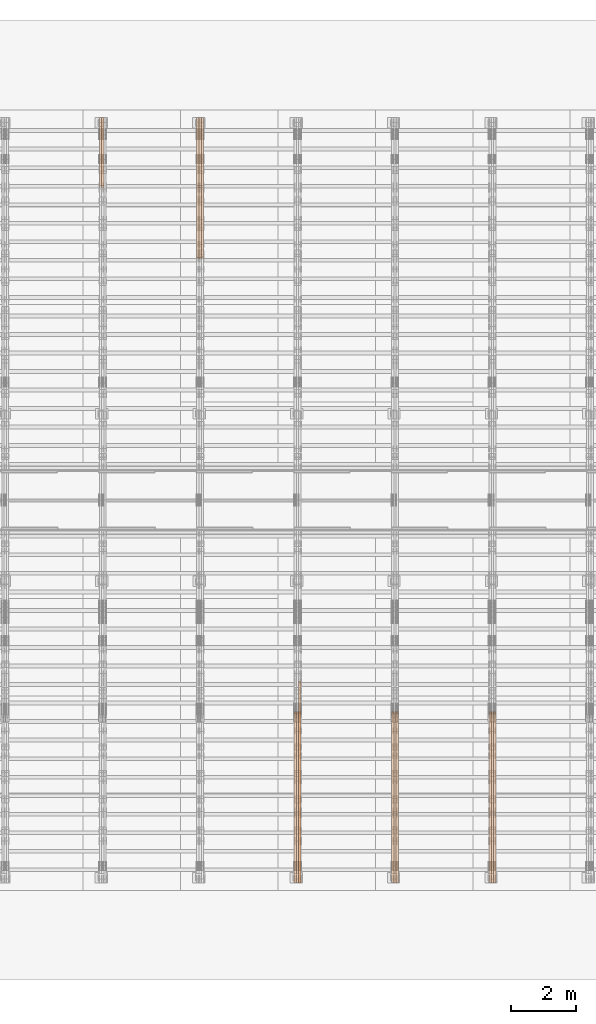
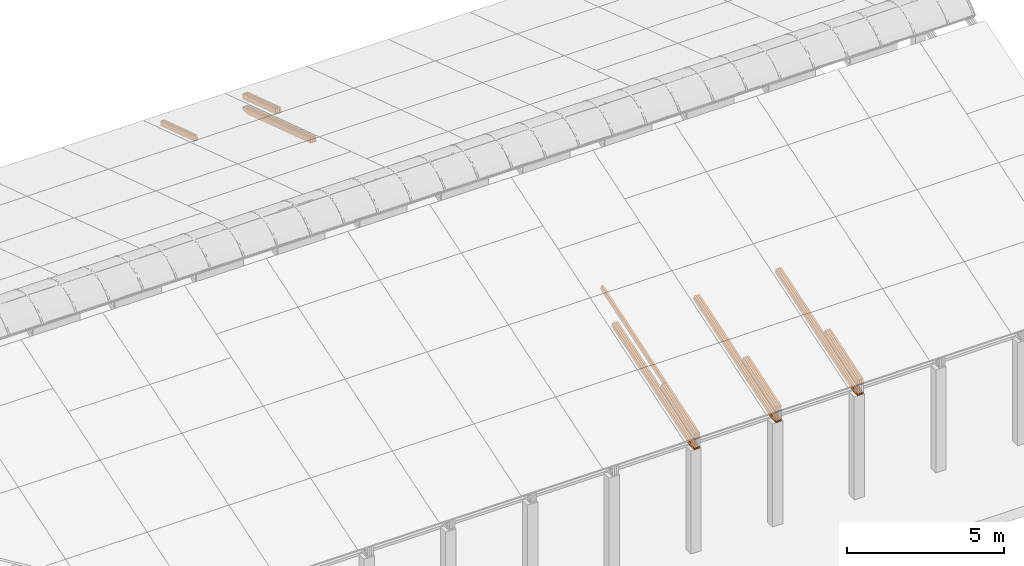
# One storey, part 24 of 385: 27 proxies.
"""IFC2X3 building model written with IfcOpenShell, lengths in millimetres."""

from ifc_helpers import new_model, entity, si_unit, converted_unit, derived_unit, direction, frame, origin, place, context, subcontext, project, spatial, polyline, outline, extrude, source, transform, mapped, material, type_object, type_shapes, element, save


model = new_model("IFC2X3")

# Units and contexts
model_context = context("Model", 3, precision=0.01, world=origin(), true_north=direction((6.12303176911189e-17, 1.0)))
body_context = subcontext(model_context, "Body", "Model", "MODEL_VIEW")
ifc_project = project(units=[si_unit("LENGTHUNIT", "METRE", prefix="MILLI"), si_unit("AREAUNIT", "SQUARE_METRE"), si_unit("VOLUMEUNIT", "CUBIC_METRE"), converted_unit("PLANEANGLEUNIT", "DEGREE", entity("IfcRatioMeasure", 0.0174532925199433), si_unit("PLANEANGLEUNIT", "RADIAN"), dimensions=[0, 0, 0, 0, 0, 0, 0]), si_unit("MASSUNIT", "GRAM", prefix="KILO"), derived_unit("MASSDENSITYUNIT", [(si_unit("MASSUNIT", "GRAM", prefix="KILO"), 1), (si_unit("LENGTHUNIT", "METRE"), -3)]), si_unit("TIMEUNIT", "SECOND"), si_unit("FREQUENCYUNIT", "HERTZ"), si_unit("THERMODYNAMICTEMPERATUREUNIT", "DEGREE_CELSIUS"), derived_unit("THERMALTRANSMITTANCEUNIT", [(si_unit("MASSUNIT", "GRAM", prefix="KILO"), 1), (si_unit("THERMODYNAMICTEMPERATUREUNIT", "KELVIN"), -1), (si_unit("TIMEUNIT", "SECOND"), -3)]), derived_unit("VOLUMETRICFLOWRATEUNIT", [(si_unit("LENGTHUNIT", "METRE"), 3), (si_unit("TIMEUNIT", "SECOND"), -1)]), si_unit("ELECTRICCURRENTUNIT", "AMPERE"), si_unit("ELECTRICVOLTAGEUNIT", "VOLT"), si_unit("POWERUNIT", "WATT"), si_unit("FORCEUNIT", "NEWTON", prefix="KILO"), si_unit("ILLUMINANCEUNIT", "LUX"), si_unit("LUMINOUSFLUXUNIT", "LUMEN"), si_unit("LUMINOUSINTENSITYUNIT", "CANDELA"), derived_unit("USERDEFINED", [(si_unit("MASSUNIT", "GRAM", prefix="KILO"), -1), (si_unit("LENGTHUNIT", "METRE"), -2), (si_unit("TIMEUNIT", "SECOND"), 3), (si_unit("LUMINOUSFLUXUNIT", "LUMEN"), 1)]), derived_unit("LINEARVELOCITYUNIT", [(si_unit("LENGTHUNIT", "METRE"), 1), (si_unit("TIMEUNIT", "SECOND"), -1)]), si_unit("PRESSUREUNIT", "PASCAL"), derived_unit("USERDEFINED", [(si_unit("LENGTHUNIT", "METRE"), -2), (si_unit("MASSUNIT", "GRAM", prefix="KILO"), 1), (si_unit("TIMEUNIT", "SECOND"), -2)])], contexts=[model_context])

# Site, building, storey
site_placement = place(None, origin())
site = spatial("IfcSite", under=ifc_project, at=site_placement, CompositionType="ELEMENT")
building_placement = place(site_placement, origin())
building = spatial("IfcBuilding", under=site, at=building_placement, CompositionType="ELEMENT")
storey_placement = place(building_placement, origin())
storey = spatial("IfcBuildingStorey", under=building, at=storey_placement, Name="Default", CompositionType="ELEMENT", Elevation=0.0)

# Proxies
ifc_material_1 = material(Name="IfcSurfaceStyle #455463")
building_element_proxy_type_1 = type_object("IfcBuildingElementProxyType", Name="T1-T3 455461", PredefinedType="NOTDEFINED", material=ifc_material_1)
shared_shape_1 = source(origin(), body_context, "Body", "SweptSolid", [
    extrude(outline(polyline([(-1085.54462735035, -97.5001496742589), (1117.22361141796, -97.5001496742589), (1117.22498157786, 97.5001496742589), (-1148.90396564547, 97.5001496742589), (-1085.54462735035, -97.5001496742589)])), frame((1117.22498157786, 97.5001496742589, 0.0), z_axis=(0.0, 0.0, 1.0), x_axis=(-1.0, 0.0, 0.0)), (0.0, 0.0, 1.0), 69.9999999999999),
])
type_shapes(building_element_proxy_type_1, [shared_shape_1])
proxy_1_placement = place(building_placement, frame((39385.0, 5095.216796875, 1095.23693847656), z_axis=(-1.0, 0.0, 0.0), x_axis=(0.0, -0.951056516295154, -0.309016994374948)))
element("IfcBuildingElementProxy", 1, at=proxy_1_placement, inside=storey, type_object=building_element_proxy_type_1, material=ifc_material_1, Name="T1-T3", context=body_context, shape_type="MappedRepresentation", body=[
    mapped(shared_shape_1, transform((0.0, 0.0, 0.0), scale=1.0)),
])
ifc_material_2 = material(Name="IfcSurfaceStyle #455406")
building_element_proxy_type_2 = type_object("IfcBuildingElementProxyType", Name="T1-T3 455404", PredefinedType="NOTDEFINED", material=ifc_material_2)
shared_shape_2 = source(origin(), body_context, "Body", "SweptSolid", [
    extrude(outline(polyline([(-1085.54462735035, -97.5001496742589), (1117.22361141796, -97.5001496742589), (1117.22498157786, 97.5001496742589), (-1148.90396564547, 97.5001496742589), (-1085.54462735035, -97.5001496742589)])), frame((1117.22498157786, 97.5001496742589, 0.0), z_axis=(0.0, 0.0, 1.0), x_axis=(-1.0, 0.0, 0.0)), (0.0, 0.0, 1.0), 69.9999999999999),
])
type_shapes(building_element_proxy_type_2, [shared_shape_2])
proxy_2_placement = place(building_placement, frame((39315.0, 5095.216796875, 1095.23693847656), z_axis=(-1.0, 0.0, 0.0), x_axis=(0.0, -0.951056516295154, -0.309016994374948)))
element("IfcBuildingElementProxy", 2, at=proxy_2_placement, inside=storey, type_object=building_element_proxy_type_2, material=ifc_material_2, Name="T1-T3", context=body_context, shape_type="MappedRepresentation", body=[
    mapped(shared_shape_2, transform((0.0, 0.0, 0.0), scale=1.0)),
])
ifc_material_3 = material(Name="IfcSurfaceStyle #455349")
building_element_proxy_type_3 = type_object("IfcBuildingElementProxyType", Name="T1-T3 455347", PredefinedType="NOTDEFINED", material=ifc_material_3)
shared_shape_3 = source(origin(), body_context, "Body", "SweptSolid", [
    extrude(outline(polyline([(-1085.54462735035, -97.5001496742589), (1117.22361141796, -97.5001496742589), (1117.22498157786, 97.5001496742589), (-1148.90396564547, 97.5001496742589), (-1085.54462735035, -97.5001496742589)])), frame((1117.22498157786, 97.5001496742589, 0.0), z_axis=(0.0, 0.0, 1.0), x_axis=(-1.0, 0.0, 0.0)), (0.0, 0.0, 1.0), 69.9999999999999),
])
type_shapes(building_element_proxy_type_3, [shared_shape_3])
proxy_3_placement = place(building_placement, frame((39245.0, 5095.216796875, 1095.23693847656), z_axis=(-1.0, 0.0, 0.0), x_axis=(0.0, -0.951056516295154, -0.309016994374948)))
element("IfcBuildingElementProxy", 3, at=proxy_3_placement, inside=storey, type_object=building_element_proxy_type_3, material=ifc_material_3, Name="T1-T3", context=body_context, shape_type="MappedRepresentation", body=[
    mapped(shared_shape_3, transform((0.0, 0.0, 0.0), scale=1.0)),
])
ifc_material_4 = material(Name="IfcSurfaceStyle #454779")
building_element_proxy_type_4 = type_object("IfcBuildingElementProxyType", Name="T1-B5 454777", PredefinedType="NOTDEFINED", material=ifc_material_4)
shared_shape_4 = source(origin(), body_context, "Body", "SweptSolid", [
    extrude(outline(polyline([(-3238.20553797979, -89.0131148793731), (1950.26357999126, -89.0131148793731), (2273.6227955316, 16.0525968934038), (2252.52438864378, 80.9868164326712), (-3238.20522618685, 80.9868164326712), (-3238.20553797979, -89.0131148793731)])), frame((2273.6227955316, 80.9869419088758, 0.0), z_axis=(0.0, 0.0, 1.0), x_axis=(-1.0, 0.0, 0.0)), (0.0, 0.0, 1.0), 69.9999999999997),
])
type_shapes(building_element_proxy_type_4, [shared_shape_4])
proxy_4_placement = place(building_placement, frame((39385.0, 2919.93418387161, 61.7562319586341), z_axis=(-1.0, 0.0, 0.0), x_axis=(0.0, 0.951056516295124, 0.309016994375039)))
element("IfcBuildingElementProxy", 4, at=proxy_4_placement, inside=storey, type_object=building_element_proxy_type_4, material=ifc_material_4, Name="T1-B5", context=body_context, shape_type="MappedRepresentation", body=[
    mapped(shared_shape_4, transform((0.0, 0.0, 0.0), scale=1.0)),
])
ifc_material_5 = material(Name="IfcSurfaceStyle #454713")
building_element_proxy_type_5 = type_object("IfcBuildingElementProxyType", Name="T1-B5 454711", PredefinedType="NOTDEFINED", material=ifc_material_5)
shared_shape_5 = source(origin(), body_context, "Body", "SweptSolid", [
    extrude(outline(polyline([(-3238.20553797979, -89.0131148793731), (1950.26357999126, -89.0131148793731), (2273.6227955316, 16.0525968934038), (2252.52438864378, 80.9868164326712), (-3238.20522618685, 80.9868164326712), (-3238.20553797979, -89.0131148793731)])), frame((2273.6227955316, 80.9869419088758, 0.0), z_axis=(0.0, 0.0, 1.0), x_axis=(-1.0, 0.0, 0.0)), (0.0, 0.0, 1.0), 69.9999999999997),
])
type_shapes(building_element_proxy_type_5, [shared_shape_5])
proxy_5_placement = place(building_placement, frame((39315.0, 2919.93418387161, 61.7562319586341), z_axis=(-1.0, 0.0, 0.0), x_axis=(0.0, 0.951056516295124, 0.309016994375039)))
element("IfcBuildingElementProxy", 5, at=proxy_5_placement, inside=storey, type_object=building_element_proxy_type_5, material=ifc_material_5, Name="T1-B5", context=body_context, shape_type="MappedRepresentation", body=[
    mapped(shared_shape_5, transform((0.0, 0.0, 0.0), scale=1.0)),
])
ifc_material_6 = material(Name="IfcSurfaceStyle #454647")
building_element_proxy_type_6 = type_object("IfcBuildingElementProxyType", Name="T1-B5 454645", PredefinedType="NOTDEFINED", material=ifc_material_6)
shared_shape_6 = source(origin(), body_context, "Body", "SweptSolid", [
    extrude(outline(polyline([(-3238.20553797979, -89.0131148793731), (1950.26357999126, -89.0131148793731), (2273.6227955316, 16.0525968934038), (2252.52438864378, 80.9868164326712), (-3238.20522618685, 80.9868164326712), (-3238.20553797979, -89.0131148793731)])), frame((2273.6227955316, 80.9869419088758, 0.0), z_axis=(0.0, 0.0, 1.0), x_axis=(-1.0, 0.0, 0.0)), (0.0, 0.0, 1.0), 69.9999999999997),
])
type_shapes(building_element_proxy_type_6, [shared_shape_6])
proxy_6_placement = place(building_placement, frame((39245.0, 2919.93418387161, 61.7562319586341), z_axis=(-1.0, 0.0, 0.0), x_axis=(0.0, 0.951056516295124, 0.309016994375039)))
element("IfcBuildingElementProxy", 6, at=proxy_6_placement, inside=storey, type_object=building_element_proxy_type_6, material=ifc_material_6, Name="T1-B5", context=body_context, shape_type="MappedRepresentation", body=[
    mapped(shared_shape_6, transform((0.0, 0.0, 0.0), scale=1.0)),
])
ifc_material_7 = material(Name="IfcSurfaceStyle #421031")
building_element_proxy_type_7 = type_object("IfcBuildingElementProxyType", Name="T1-T3 421029", PredefinedType="NOTDEFINED", material=ifc_material_7)
shared_shape_7 = source(origin(), body_context, "Body", "SweptSolid", [
    extrude(outline(polyline([(-1085.54462735035, -97.5001496742589), (1117.22361141796, -97.5001496742589), (1117.22498157786, 97.5001496742589), (-1148.90396564547, 97.5001496742589), (-1085.54462735035, -97.5001496742589)])), frame((1117.22498157786, 97.5001496742589, 0.0), z_axis=(0.0, 0.0, 1.0), x_axis=(-1.0, 0.0, 0.0)), (0.0, 0.0, 1.0), 69.9999999999999),
])
type_shapes(building_element_proxy_type_7, [shared_shape_7])
proxy_7_placement = place(building_placement, frame((36385.0, 5095.216796875, 1095.23693847656), z_axis=(-1.0, 0.0, 0.0), x_axis=(0.0, -0.951056516295154, -0.309016994374948)))
element("IfcBuildingElementProxy", 7, at=proxy_7_placement, inside=storey, type_object=building_element_proxy_type_7, material=ifc_material_7, Name="T1-T3", context=body_context, shape_type="MappedRepresentation", body=[
    mapped(shared_shape_7, transform((0.0, 0.0, 0.0), scale=1.0)),
])
ifc_material_8 = material(Name="IfcSurfaceStyle #420974")
building_element_proxy_type_8 = type_object("IfcBuildingElementProxyType", Name="T1-T3 420972", PredefinedType="NOTDEFINED", material=ifc_material_8)
shared_shape_8 = source(origin(), body_context, "Body", "SweptSolid", [
    extrude(outline(polyline([(-1085.54462735035, -97.5001496742589), (1117.22361141796, -97.5001496742589), (1117.22498157786, 97.5001496742589), (-1148.90396564547, 97.5001496742589), (-1085.54462735035, -97.5001496742589)])), frame((1117.22498157786, 97.5001496742589, 0.0), z_axis=(0.0, 0.0, 1.0), x_axis=(-1.0, 0.0, 0.0)), (0.0, 0.0, 1.0), 69.9999999999999),
])
type_shapes(building_element_proxy_type_8, [shared_shape_8])
proxy_8_placement = place(building_placement, frame((36315.0, 5095.216796875, 1095.23693847656), z_axis=(-1.0, 0.0, 0.0), x_axis=(0.0, -0.951056516295154, -0.309016994374948)))
element("IfcBuildingElementProxy", 8, at=proxy_8_placement, inside=storey, type_object=building_element_proxy_type_8, material=ifc_material_8, Name="T1-T3", context=body_context, shape_type="MappedRepresentation", body=[
    mapped(shared_shape_8, transform((0.0, 0.0, 0.0), scale=1.0)),
])
ifc_material_9 = material(Name="IfcSurfaceStyle #420917")
building_element_proxy_type_9 = type_object("IfcBuildingElementProxyType", Name="T1-T3 420915", PredefinedType="NOTDEFINED", material=ifc_material_9)
shared_shape_9 = source(origin(), body_context, "Body", "SweptSolid", [
    extrude(outline(polyline([(-1085.54462735035, -97.5001496742589), (1117.22361141796, -97.5001496742589), (1117.22498157786, 97.5001496742589), (-1148.90396564547, 97.5001496742589), (-1085.54462735035, -97.5001496742589)])), frame((1117.22498157786, 97.5001496742589, 0.0), z_axis=(0.0, 0.0, 1.0), x_axis=(-1.0, 0.0, 0.0)), (0.0, 0.0, 1.0), 69.9999999999999),
])
type_shapes(building_element_proxy_type_9, [shared_shape_9])
proxy_9_placement = place(building_placement, frame((36245.0, 5095.216796875, 1095.23693847656), z_axis=(-1.0, 0.0, 0.0), x_axis=(0.0, -0.951056516295154, -0.309016994374948)))
element("IfcBuildingElementProxy", 9, at=proxy_9_placement, inside=storey, type_object=building_element_proxy_type_9, material=ifc_material_9, Name="T1-T3", context=body_context, shape_type="MappedRepresentation", body=[
    mapped(shared_shape_9, transform((0.0, 0.0, 0.0), scale=1.0)),
])
ifc_material_10 = material(Name="IfcSurfaceStyle #420347")
building_element_proxy_type_10 = type_object("IfcBuildingElementProxyType", Name="T1-B5 420345", PredefinedType="NOTDEFINED", material=ifc_material_10)
shared_shape_10 = source(origin(), body_context, "Body", "SweptSolid", [
    extrude(outline(polyline([(-3238.20553797979, -89.0131148793731), (1950.26357999126, -89.0131148793731), (2273.6227955316, 16.0525968934038), (2252.52438864378, 80.9868164326712), (-3238.20522618685, 80.9868164326712), (-3238.20553797979, -89.0131148793731)])), frame((2273.6227955316, 80.9869419088758, 0.0), z_axis=(0.0, 0.0, 1.0), x_axis=(-1.0, 0.0, 0.0)), (0.0, 0.0, 1.0), 69.9999999999997),
])
type_shapes(building_element_proxy_type_10, [shared_shape_10])
proxy_10_placement = place(building_placement, frame((36385.0, 2919.93418387161, 61.7562319586341), z_axis=(-1.0, 0.0, 0.0), x_axis=(0.0, 0.951056516295124, 0.309016994375039)))
element("IfcBuildingElementProxy", 10, at=proxy_10_placement, inside=storey, type_object=building_element_proxy_type_10, material=ifc_material_10, Name="T1-B5", context=body_context, shape_type="MappedRepresentation", body=[
    mapped(shared_shape_10, transform((0.0, 0.0, 0.0), scale=1.0)),
])
ifc_material_11 = material(Name="IfcSurfaceStyle #420281")
building_element_proxy_type_11 = type_object("IfcBuildingElementProxyType", Name="T1-B5 420279", PredefinedType="NOTDEFINED", material=ifc_material_11)
shared_shape_11 = source(origin(), body_context, "Body", "SweptSolid", [
    extrude(outline(polyline([(-3238.20553797979, -89.0131148793731), (1950.26357999126, -89.0131148793731), (2273.6227955316, 16.0525968934038), (2252.52438864378, 80.9868164326712), (-3238.20522618685, 80.9868164326712), (-3238.20553797979, -89.0131148793731)])), frame((2273.6227955316, 80.9869419088758, 0.0), z_axis=(0.0, 0.0, 1.0), x_axis=(-1.0, 0.0, 0.0)), (0.0, 0.0, 1.0), 69.9999999999997),
])
type_shapes(building_element_proxy_type_11, [shared_shape_11])
proxy_11_placement = place(building_placement, frame((36315.0, 2919.93418387161, 61.7562319586341), z_axis=(-1.0, 0.0, 0.0), x_axis=(0.0, 0.951056516295124, 0.309016994375039)))
element("IfcBuildingElementProxy", 11, at=proxy_11_placement, inside=storey, type_object=building_element_proxy_type_11, material=ifc_material_11, Name="T1-B5", context=body_context, shape_type="MappedRepresentation", body=[
    mapped(shared_shape_11, transform((0.0, 0.0, 0.0), scale=1.0)),
])
ifc_material_12 = material(Name="IfcSurfaceStyle #420215")
building_element_proxy_type_12 = type_object("IfcBuildingElementProxyType", Name="T1-B5 420213", PredefinedType="NOTDEFINED", material=ifc_material_12)
shared_shape_12 = source(origin(), body_context, "Body", "SweptSolid", [
    extrude(outline(polyline([(-3238.20553797979, -89.0131148793731), (1950.26357999126, -89.0131148793731), (2273.6227955316, 16.0525968934038), (2252.52438864378, 80.9868164326712), (-3238.20522618685, 80.9868164326712), (-3238.20553797979, -89.0131148793731)])), frame((2273.6227955316, 80.9869419088758, 0.0), z_axis=(0.0, 0.0, 1.0), x_axis=(-1.0, 0.0, 0.0)), (0.0, 0.0, 1.0), 69.9999999999997),
])
type_shapes(building_element_proxy_type_12, [shared_shape_12])
proxy_12_placement = place(building_placement, frame((36245.0, 2919.93418387161, 61.7562319586341), z_axis=(-1.0, 0.0, 0.0), x_axis=(0.0, 0.951056516295124, 0.309016994375039)))
element("IfcBuildingElementProxy", 12, at=proxy_12_placement, inside=storey, type_object=building_element_proxy_type_12, material=ifc_material_12, Name="T1-B5", context=body_context, shape_type="MappedRepresentation", body=[
    mapped(shared_shape_12, transform((0.0, 0.0, 0.0), scale=1.0)),
])
ifc_material_13 = material(Name="IfcSurfaceStyle #386599")
building_element_proxy_type_13 = type_object("IfcBuildingElementProxyType", Name="T1-T3 386597", PredefinedType="NOTDEFINED", material=ifc_material_13)
shared_shape_13 = source(origin(), body_context, "Body", "SweptSolid", [
    extrude(outline(polyline([(-1085.54462735035, -97.5001496742589), (1117.22361141796, -97.5001496742589), (1117.22498157786, 97.5001496742589), (-1148.90396564547, 97.5001496742589), (-1085.54462735035, -97.5001496742589)])), frame((1117.22498157786, 97.5001496742589, 0.0), z_axis=(0.0, 0.0, 1.0), x_axis=(-1.0, 0.0, 0.0)), (0.0, 0.0, 1.0), 69.9999999999999),
])
type_shapes(building_element_proxy_type_13, [shared_shape_13])
proxy_13_placement = place(building_placement, frame((33385.0, 5095.216796875, 1095.23693847656), z_axis=(-1.0, 0.0, 0.0), x_axis=(0.0, -0.951056516295154, -0.309016994374948)))
element("IfcBuildingElementProxy", 13, at=proxy_13_placement, inside=storey, type_object=building_element_proxy_type_13, material=ifc_material_13, Name="T1-T3", context=body_context, shape_type="MappedRepresentation", body=[
    mapped(shared_shape_13, transform((0.0, 0.0, 0.0), scale=1.0)),
])
ifc_material_14 = material(Name="IfcSurfaceStyle #386542")
building_element_proxy_type_14 = type_object("IfcBuildingElementProxyType", Name="T1-T3 386540", PredefinedType="NOTDEFINED", material=ifc_material_14)
shared_shape_14 = source(origin(), body_context, "Body", "SweptSolid", [
    extrude(outline(polyline([(-1085.54462735035, -97.5001496742589), (1117.22361141796, -97.5001496742589), (1117.22498157786, 97.5001496742589), (-1148.90396564547, 97.5001496742589), (-1085.54462735035, -97.5001496742589)])), frame((1117.22498157786, 97.5001496742589, 0.0), z_axis=(0.0, 0.0, 1.0), x_axis=(-1.0, 0.0, 0.0)), (0.0, 0.0, 1.0), 69.9999999999999),
])
type_shapes(building_element_proxy_type_14, [shared_shape_14])
proxy_14_placement = place(building_placement, frame((33315.0, 5095.216796875, 1095.23693847656), z_axis=(-1.0, 0.0, 0.0), x_axis=(0.0, -0.951056516295154, -0.309016994374948)))
element("IfcBuildingElementProxy", 14, at=proxy_14_placement, inside=storey, type_object=building_element_proxy_type_14, material=ifc_material_14, Name="T1-T3", context=body_context, shape_type="MappedRepresentation", body=[
    mapped(shared_shape_14, transform((0.0, 0.0, 0.0), scale=1.0)),
])
ifc_material_15 = material(Name="IfcSurfaceStyle #386485")
building_element_proxy_type_15 = type_object("IfcBuildingElementProxyType", Name="T1-T3 386483", PredefinedType="NOTDEFINED", material=ifc_material_15)
shared_shape_15 = source(origin(), body_context, "Body", "SweptSolid", [
    extrude(outline(polyline([(-1085.54462735035, -97.5001496742589), (1117.22361141796, -97.5001496742589), (1117.22498157786, 97.5001496742589), (-1148.90396564547, 97.5001496742589), (-1085.54462735035, -97.5001496742589)])), frame((1117.22498157786, 97.5001496742589, 0.0), z_axis=(0.0, 0.0, 1.0), x_axis=(-1.0, 0.0, 0.0)), (0.0, 0.0, 1.0), 69.9999999999999),
])
type_shapes(building_element_proxy_type_15, [shared_shape_15])
proxy_15_placement = place(building_placement, frame((33245.0, 5095.216796875, 1095.23693847656), z_axis=(-1.0, 0.0, 0.0), x_axis=(0.0, -0.951056516295154, -0.309016994374948)))
element("IfcBuildingElementProxy", 15, at=proxy_15_placement, inside=storey, type_object=building_element_proxy_type_15, material=ifc_material_15, Name="T1-T3", context=body_context, shape_type="MappedRepresentation", body=[
    mapped(shared_shape_15, transform((0.0, 0.0, 0.0), scale=1.0)),
])
ifc_material_16 = material(Name="IfcSurfaceStyle #386428")
building_element_proxy_type_16 = type_object("IfcBuildingElementProxyType", Name="T1-T2 386426", PredefinedType="NOTDEFINED", material=ifc_material_16)
shared_shape_16 = source(origin(), body_context, "Body", "SweptSolid", [
    extrude(outline(polyline([(-2137.04475371072, -97.5001541485635), (2137.04431231695, -97.5001541485635), (2137.0438249446, 97.5001541485636), (-2137.04338355082, 97.5001541485635), (-2137.04475371072, -97.5001541485635)])), frame((2137.04431231695, 97.5003268035489, 0.0), z_axis=(0.0, 0.0, 1.0), x_axis=(-1.0, 0.0, 0.0)), (0.0, 0.0, 1.0), 69.9999999999997),
])
type_shapes(building_element_proxy_type_16, [shared_shape_16])
proxy_16_placement = place(building_placement, frame((33385.0, 9160.11575124697, 2416.00267194857), z_axis=(-1.0, 0.0, 0.0), x_axis=(0.0, -0.951056516295154, -0.309016994374948)))
element("IfcBuildingElementProxy", 16, at=proxy_16_placement, inside=storey, type_object=building_element_proxy_type_16, material=ifc_material_16, Name="T1-T2", context=body_context, shape_type="MappedRepresentation", body=[
    mapped(shared_shape_16, transform((0.0, 0.0, 0.0), scale=1.0)),
])
ifc_material_17 = material(Name="IfcSurfaceStyle #385915")
building_element_proxy_type_17 = type_object("IfcBuildingElementProxyType", Name="T1-B5 385913", PredefinedType="NOTDEFINED", material=ifc_material_17)
shared_shape_17 = source(origin(), body_context, "Body", "SweptSolid", [
    extrude(outline(polyline([(-3238.20553797979, -89.0131148793731), (1950.26357999126, -89.0131148793731), (2273.6227955316, 16.0525968934038), (2252.52438864378, 80.9868164326712), (-3238.20522618685, 80.9868164326712), (-3238.20553797979, -89.0131148793731)])), frame((2273.6227955316, 80.9869419088758, 0.0), z_axis=(0.0, 0.0, 1.0), x_axis=(-1.0, 0.0, 0.0)), (0.0, 0.0, 1.0), 69.9999999999997),
])
type_shapes(building_element_proxy_type_17, [shared_shape_17])
proxy_17_placement = place(building_placement, frame((33385.0, 2919.93418387161, 61.7562319586341), z_axis=(-1.0, 0.0, 0.0), x_axis=(0.0, 0.951056516295124, 0.309016994375039)))
element("IfcBuildingElementProxy", 17, at=proxy_17_placement, inside=storey, type_object=building_element_proxy_type_17, material=ifc_material_17, Name="T1-B5", context=body_context, shape_type="MappedRepresentation", body=[
    mapped(shared_shape_17, transform((0.0, 0.0, 0.0), scale=1.0)),
])
ifc_material_18 = material(Name="IfcSurfaceStyle #385849")
building_element_proxy_type_18 = type_object("IfcBuildingElementProxyType", Name="T1-B5 385847", PredefinedType="NOTDEFINED", material=ifc_material_18)
shared_shape_18 = source(origin(), body_context, "Body", "SweptSolid", [
    extrude(outline(polyline([(-3238.20553797979, -89.0131148793731), (1950.26357999126, -89.0131148793731), (2273.6227955316, 16.0525968934038), (2252.52438864378, 80.9868164326712), (-3238.20522618685, 80.9868164326712), (-3238.20553797979, -89.0131148793731)])), frame((2273.6227955316, 80.9869419088758, 0.0), z_axis=(0.0, 0.0, 1.0), x_axis=(-1.0, 0.0, 0.0)), (0.0, 0.0, 1.0), 69.9999999999997),
])
type_shapes(building_element_proxy_type_18, [shared_shape_18])
proxy_18_placement = place(building_placement, frame((33315.0, 2919.93418387161, 61.7562319586341), z_axis=(-1.0, 0.0, 0.0), x_axis=(0.0, 0.951056516295124, 0.309016994375039)))
element("IfcBuildingElementProxy", 18, at=proxy_18_placement, inside=storey, type_object=building_element_proxy_type_18, material=ifc_material_18, Name="T1-B5", context=body_context, shape_type="MappedRepresentation", body=[
    mapped(shared_shape_18, transform((0.0, 0.0, 0.0), scale=1.0)),
])
ifc_material_19 = material(Name="IfcSurfaceStyle #385783")
building_element_proxy_type_19 = type_object("IfcBuildingElementProxyType", Name="T1-B5 385781", PredefinedType="NOTDEFINED", material=ifc_material_19)
shared_shape_19 = source(origin(), body_context, "Body", "SweptSolid", [
    extrude(outline(polyline([(-3238.20553797979, -89.0131148793731), (1950.26357999126, -89.0131148793731), (2273.6227955316, 16.0525968934038), (2252.52438864378, 80.9868164326712), (-3238.20522618685, 80.9868164326712), (-3238.20553797979, -89.0131148793731)])), frame((2273.6227955316, 80.9869419088758, 0.0), z_axis=(0.0, 0.0, 1.0), x_axis=(-1.0, 0.0, 0.0)), (0.0, 0.0, 1.0), 69.9999999999997),
])
type_shapes(building_element_proxy_type_19, [shared_shape_19])
proxy_19_placement = place(building_placement, frame((33245.0, 2919.93418387161, 61.7562319586341), z_axis=(-1.0, 0.0, 0.0), x_axis=(0.0, 0.951056516295124, 0.309016994375039)))
element("IfcBuildingElementProxy", 19, at=proxy_19_placement, inside=storey, type_object=building_element_proxy_type_19, material=ifc_material_19, Name="T1-B5", context=body_context, shape_type="MappedRepresentation", body=[
    mapped(shared_shape_19, transform((0.0, 0.0, 0.0), scale=1.0)),
])
ifc_material_20 = material(Name="IfcSurfaceStyle #352338")
building_element_proxy_type_20 = type_object("IfcBuildingElementProxyType", Name="T1-T3 352336", PredefinedType="NOTDEFINED", material=ifc_material_20)
shared_shape_20 = source(origin(), body_context, "Body", "SweptSolid", [
    extrude(outline(polyline([(-1117.22419189679, -97.5000115568039), (1085.54451125458, -97.5000115568039), (1148.90384954971, 97.5000115568039), (-1117.2241689075, 97.5000115568039), (-1117.22419189679, -97.5000115568039)])), frame((1148.90385201956, 97.5000191595882, 0.0), z_axis=(0.0, 0.0, 1.0), x_axis=(-1.0, 0.0, 0.0)), (0.0, 0.0, 1.0), 69.9999999999999),
])
type_shapes(building_element_proxy_type_20, [shared_shape_20])
proxy_20_placement = place(building_placement, frame((30385.0, 26500.0, 394.964866273674), z_axis=(-1.0, 0.0, 0.0), x_axis=(0.0, -0.951056516295154, 0.309016994374948)))
element("IfcBuildingElementProxy", 20, at=proxy_20_placement, inside=storey, type_object=building_element_proxy_type_20, material=ifc_material_20, Name="T1-T3", context=body_context, shape_type="MappedRepresentation", body=[
    mapped(shared_shape_20, transform((0.0, 0.0, 0.0), scale=1.0)),
])
ifc_material_21 = material(Name="IfcSurfaceStyle #352281")
building_element_proxy_type_21 = type_object("IfcBuildingElementProxyType", Name="T1-T3 352279", PredefinedType="NOTDEFINED", material=ifc_material_21)
shared_shape_21 = source(origin(), body_context, "Body", "SweptSolid", [
    extrude(outline(polyline([(-1117.22419189679, -97.5000115568039), (1085.54451125458, -97.5000115568039), (1148.90384954971, 97.5000115568039), (-1117.2241689075, 97.5000115568039), (-1117.22419189679, -97.5000115568039)])), frame((1148.90385201956, 97.5000191595882, 0.0), z_axis=(0.0, 0.0, 1.0), x_axis=(-1.0, 0.0, 0.0)), (0.0, 0.0, 1.0), 69.9999999999999),
])
type_shapes(building_element_proxy_type_21, [shared_shape_21])
proxy_21_placement = place(building_placement, frame((30315.0, 26500.0, 394.964866273674), z_axis=(-1.0, 0.0, 0.0), x_axis=(0.0, -0.951056516295154, 0.309016994374948)))
element("IfcBuildingElementProxy", 21, at=proxy_21_placement, inside=storey, type_object=building_element_proxy_type_21, material=ifc_material_21, Name="T1-T3", context=body_context, shape_type="MappedRepresentation", body=[
    mapped(shared_shape_21, transform((0.0, 0.0, 0.0), scale=1.0)),
])
ifc_material_22 = material(Name="IfcSurfaceStyle #352224")
building_element_proxy_type_22 = type_object("IfcBuildingElementProxyType", Name="T1-T3 352222", PredefinedType="NOTDEFINED", material=ifc_material_22)
shared_shape_22 = source(origin(), body_context, "Body", "SweptSolid", [
    extrude(outline(polyline([(-1117.22419189679, -97.5000115568039), (1085.54451125458, -97.5000115568039), (1148.90384954971, 97.5000115568039), (-1117.2241689075, 97.5000115568039), (-1117.22419189679, -97.5000115568039)])), frame((1148.90385201956, 97.5000191595882, 0.0), z_axis=(0.0, 0.0, 1.0), x_axis=(-1.0, 0.0, 0.0)), (0.0, 0.0, 1.0), 69.9999999999999),
])
type_shapes(building_element_proxy_type_22, [shared_shape_22])
proxy_22_placement = place(building_placement, frame((30245.0, 26500.0, 394.964866273674), z_axis=(-1.0, 0.0, 0.0), x_axis=(0.0, -0.951056516295154, 0.309016994374948)))
element("IfcBuildingElementProxy", 22, at=proxy_22_placement, inside=storey, type_object=building_element_proxy_type_22, material=ifc_material_22, Name="T1-T3", context=body_context, shape_type="MappedRepresentation", body=[
    mapped(shared_shape_22, transform((0.0, 0.0, 0.0), scale=1.0)),
])
ifc_material_23 = material(Name="IfcSurfaceStyle #350943")
building_element_proxy_type_23 = type_object("IfcBuildingElementProxyType", Name="T1-B1 350941", PredefinedType="NOTDEFINED", material=ifc_material_23)
shared_shape_23 = source(origin(), body_context, "Body", "SweptSolid", [
    extrude(outline(polyline([(-2659.34106034305, -95.9868650736445), (1861.19950396595, -95.9868650736445), (1890.42090463564, -6.05260867570997), (1567.0616890952, 99.0131694114995), (-2659.34103735375, 99.0131694114995), (-2659.34106034305, -95.9868650736445)])), frame((1890.42090463564, 99.013169411504, 0.0), z_axis=(0.0, 0.0, 1.0), x_axis=(-1.0, 0.0, 0.0)), (0.0, 0.0, 1.0), 69.9999999999997),
])
type_shapes(building_element_proxy_type_23, [shared_shape_23])
proxy_23_placement = place(building_placement, frame((30385.0, 26467.5328890438, -99.9234928894624), z_axis=(-1.0, 0.0, 0.0), x_axis=(0.0, -0.951056516295124, 0.309016994375039)))
element("IfcBuildingElementProxy", 23, at=proxy_23_placement, inside=storey, type_object=building_element_proxy_type_23, material=ifc_material_23, Name="T1-B1", context=body_context, shape_type="MappedRepresentation", body=[
    mapped(shared_shape_23, transform((0.0, 0.0, 0.0), scale=1.0)),
])
ifc_material_24 = material(Name="IfcSurfaceStyle #350877")
building_element_proxy_type_24 = type_object("IfcBuildingElementProxyType", Name="T1-B1 350875", PredefinedType="NOTDEFINED", material=ifc_material_24)
shared_shape_24 = source(origin(), body_context, "Body", "SweptSolid", [
    extrude(outline(polyline([(-2659.34106034305, -95.9868650736445), (1861.19950396595, -95.9868650736445), (1890.42090463564, -6.05260867570997), (1567.0616890952, 99.0131694114995), (-2659.34103735375, 99.0131694114995), (-2659.34106034305, -95.9868650736445)])), frame((1890.42090463564, 99.013169411504, 0.0), z_axis=(0.0, 0.0, 1.0), x_axis=(-1.0, 0.0, 0.0)), (0.0, 0.0, 1.0), 69.9999999999997),
])
type_shapes(building_element_proxy_type_24, [shared_shape_24])
proxy_24_placement = place(building_placement, frame((30315.0, 26467.5328890438, -99.9234928894624), z_axis=(-1.0, 0.0, 0.0), x_axis=(0.0, -0.951056516295124, 0.309016994375039)))
element("IfcBuildingElementProxy", 24, at=proxy_24_placement, inside=storey, type_object=building_element_proxy_type_24, material=ifc_material_24, Name="T1-B1", context=body_context, shape_type="MappedRepresentation", body=[
    mapped(shared_shape_24, transform((0.0, 0.0, 0.0), scale=1.0)),
])
ifc_material_25 = material(Name="IfcSurfaceStyle #350811")
building_element_proxy_type_25 = type_object("IfcBuildingElementProxyType", Name="T1-B1 350809", PredefinedType="NOTDEFINED", material=ifc_material_25)
shared_shape_25 = source(origin(), body_context, "Body", "SweptSolid", [
    extrude(outline(polyline([(-2659.34106034305, -95.9868650736445), (1861.19950396595, -95.9868650736445), (1890.42090463564, -6.05260867570997), (1567.0616890952, 99.0131694114995), (-2659.34103735375, 99.0131694114995), (-2659.34106034305, -95.9868650736445)])), frame((1890.42090463564, 99.013169411504, 0.0), z_axis=(0.0, 0.0, 1.0), x_axis=(-1.0, 0.0, 0.0)), (0.0, 0.0, 1.0), 69.9999999999997),
])
type_shapes(building_element_proxy_type_25, [shared_shape_25])
proxy_25_placement = place(building_placement, frame((30245.0, 26467.5328890438, -99.9234928894624), z_axis=(-1.0, 0.0, 0.0), x_axis=(0.0, -0.951056516295124, 0.309016994375039)))
element("IfcBuildingElementProxy", 25, at=proxy_25_placement, inside=storey, type_object=building_element_proxy_type_25, material=ifc_material_25, Name="T1-B1", context=body_context, shape_type="MappedRepresentation", body=[
    mapped(shared_shape_25, transform((0.0, 0.0, 0.0), scale=1.0)),
])
ifc_material_26 = material(Name="IfcSurfaceStyle #317849")
building_element_proxy_type_26 = type_object("IfcBuildingElementProxyType", Name="T1-T3 317847", PredefinedType="NOTDEFINED", material=ifc_material_26)
shared_shape_26 = source(origin(), body_context, "Body", "SweptSolid", [
    extrude(outline(polyline([(-1117.22419189679, -97.5000115568039), (1085.54451125458, -97.5000115568039), (1148.90384954971, 97.5000115568039), (-1117.2241689075, 97.5000115568039), (-1117.22419189679, -97.5000115568039)])), frame((1148.90385201956, 97.5000191595882, 0.0), z_axis=(0.0, 0.0, 1.0), x_axis=(-1.0, 0.0, 0.0)), (0.0, 0.0, 1.0), 69.9999999999999),
])
type_shapes(building_element_proxy_type_26, [shared_shape_26])
proxy_26_placement = place(building_placement, frame((27315.0, 26500.0, 394.964866273674), z_axis=(-1.0, 0.0, 0.0), x_axis=(0.0, -0.951056516295154, 0.309016994374948)))
element("IfcBuildingElementProxy", 26, at=proxy_26_placement, inside=storey, type_object=building_element_proxy_type_26, material=ifc_material_26, Name="T1-T3", context=body_context, shape_type="MappedRepresentation", body=[
    mapped(shared_shape_26, transform((0.0, 0.0, 0.0), scale=1.0)),
])
ifc_material_27 = material(Name="IfcSurfaceStyle #317792")
building_element_proxy_type_27 = type_object("IfcBuildingElementProxyType", Name="T1-T3 317790", PredefinedType="NOTDEFINED", material=ifc_material_27)
shared_shape_27 = source(origin(), body_context, "Body", "SweptSolid", [
    extrude(outline(polyline([(-1117.22419189679, -97.5000115568039), (1085.54451125458, -97.5000115568039), (1148.90384954971, 97.5000115568039), (-1117.2241689075, 97.5000115568039), (-1117.22419189679, -97.5000115568039)])), frame((1148.90385201956, 97.5000191595882, 0.0), z_axis=(0.0, 0.0, 1.0), x_axis=(-1.0, 0.0, 0.0)), (0.0, 0.0, 1.0), 69.9999999999999),
])
type_shapes(building_element_proxy_type_27, [shared_shape_27])
proxy_27_placement = place(building_placement, frame((27245.0, 26500.0, 394.964866273674), z_axis=(-1.0, 0.0, 0.0), x_axis=(0.0, -0.951056516295154, 0.309016994374948)))
element("IfcBuildingElementProxy", 27, at=proxy_27_placement, inside=storey, type_object=building_element_proxy_type_27, material=ifc_material_27, Name="T1-T3", context=body_context, shape_type="MappedRepresentation", body=[
    mapped(shared_shape_27, transform((0.0, 0.0, 0.0), scale=1.0)),
])

save(model, "model.ifc")
